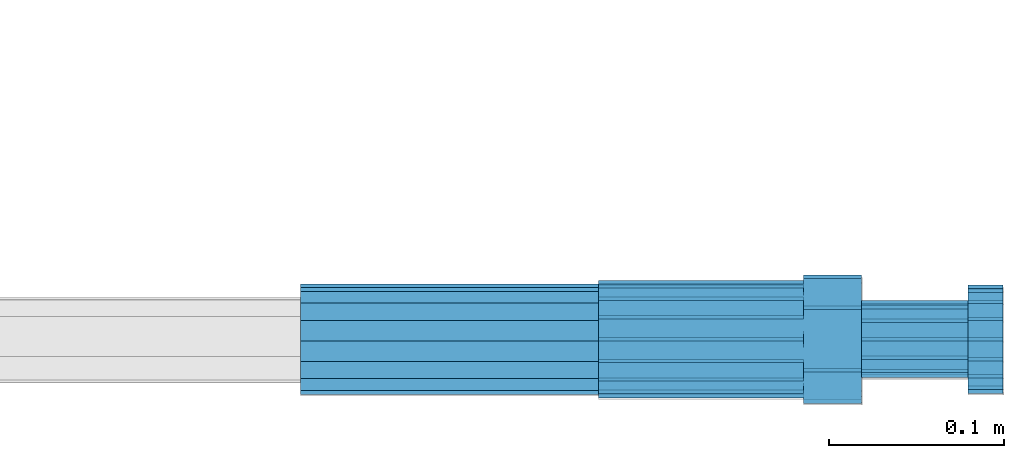
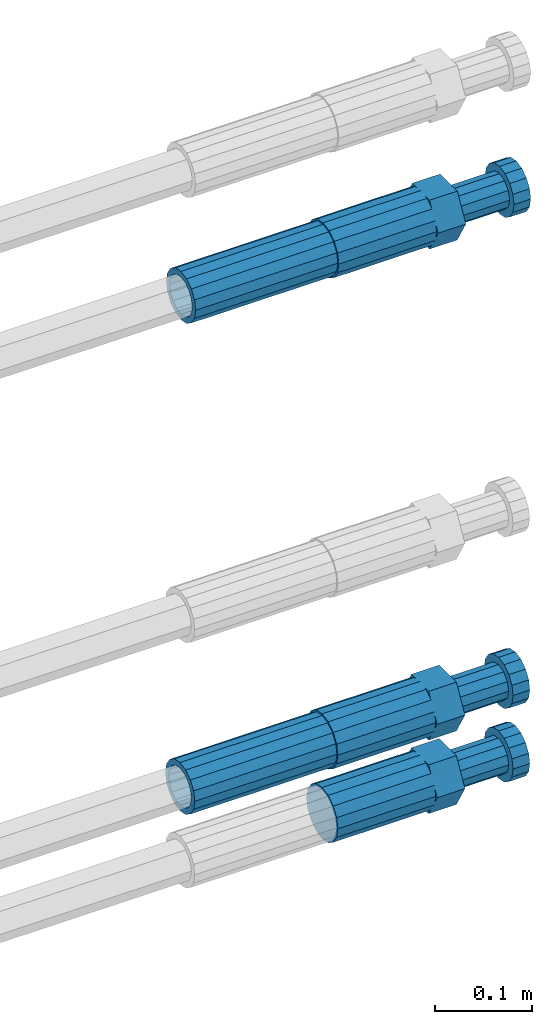
# One storey, part 106 of 177: 5 beams.
"""IFC2X3 building model written with IfcOpenShell, lengths in millimetres."""

from ifc_helpers import new_model, si_unit, frame, origin_with_axes, place, context, subcontext, project, spatial, faceted_brep, material, type_object, element, save


model = new_model("IFC2X3")

# Units and contexts
model_context_1 = context("Model", 3, precision=1e-05, world=origin_with_axes())
model_context_2 = context("Model", 3, precision=1e-05, world=origin_with_axes())
body_context = subcontext(model_context_2, "Body", "Model", "MODEL_VIEW")
ifc_project = project(units=[si_unit("LENGTHUNIT", "METRE", prefix="MILLI"), si_unit("AREAUNIT", "SQUARE_METRE"), si_unit("VOLUMEUNIT", "CUBIC_METRE"), si_unit("MASSUNIT", "GRAM", prefix="KILO"), si_unit("TIMEUNIT", "SECOND"), si_unit("PLANEANGLEUNIT", "RADIAN"), si_unit("SOLIDANGLEUNIT", "STERADIAN"), si_unit("THERMODYNAMICTEMPERATUREUNIT", "DEGREE_CELSIUS"), si_unit("LUMINOUSINTENSITYUNIT", "LUMEN")], contexts=[model_context_1])

# Site, building, storey
site_placement = place(None, origin_with_axes())
site = spatial("IfcSite", under=ifc_project, at=site_placement, CompositionType="ELEMENT")
building_placement = place(site_placement, origin_with_axes())
building = spatial("IfcBuilding", under=site, at=building_placement, Name="Undefined", CompositionType="ELEMENT")
storey_placement = place(building_placement, origin_with_axes())
storey = spatial("IfcBuildingStorey", under=building, at=storey_placement, Name="Undefined", CompositionType="ELEMENT", Elevation=0.0)

# Beams
ifc_material = material(Name="STEEL/S275")
beam_type_1 = type_object("IfcBeamType", PredefinedType="NOTDEFINED")
beam_1_placement = place(storey_placement, frame((2039349.04037948, 6205100.91588036, 18690.9968004305), z_axis=(0.0, 0.0, -1.0), x_axis=(1.0, 0.0, 0.0)))
element("IfcBeam", 1, at=beam_1_placement, inside=storey, type_object=beam_type_1, material=ifc_material, Name="AG40N", context=body_context, shape_type="Brep", body=[
    faceted_brep([(0.0, -23.5000000001164, -9.31322574615479e-10), (0.0, -21.7111690140155, 8.99306066054851), (170.0, -21.7111690140155, 8.99306066054851), (170.0, -23.5, 0.0), (0.0, -16.6170093578839, 16.6170093575493), (170.0, -16.6170093578839, 16.6170093575493), (0.0, -8.99306066057943, 21.7111690137535), (170.0, -8.99306066057943, 21.7111690137535), (0.0, 1.16415321826935e-10, 23.5), (170.0, 0.0, 23.5), (0.0, 8.99306066057943, 21.7111690137535), (170.0, 8.99306066057943, 21.7111690137535), (0.0, 16.6170093578839, 16.6170093575493), (170.0, 16.6170093578839, 16.6170093575493), (0.0, 21.7111690140155, 8.99306066054851), (170.0, 21.7111690140155, 8.99306066054851), (0.0, 23.5000000001164, -9.31322574615479e-10), (170.0, 23.5, 0.0), (0.0, 21.7111690140155, -8.99306066054851), (170.0, 21.7111690140155, -8.99306066054851), (0.0, 16.6170093578839, -16.6170093575493), (170.0, 16.6170093578839, -16.6170093575493), (0.0, 8.99306066057943, -21.7111690137535), (170.0, 8.99306066057943, -21.7111690137535), (0.0, 1.16415321826935e-10, -23.5000000009313), (170.0, 0.0, -23.5), (0.0, -8.99306066057943, -21.7111690137535), (170.0, -8.99306066057943, -21.7111690137535), (0.0, -16.6170093578839, -16.6170093575493), (170.0, -16.6170093578839, -16.6170093575493), (0.0, -21.7111690140155, -8.99306066054851), (170.0, -21.7111690140155, -8.99306066054851), (0.0, -30.5, 0.0), (0.0, -28.1783257415937, -11.6718446873128), (170.0, -28.1783257415937, -11.6718446873128), (170.0, -30.5, 0.0), (0.0, -21.5667568261888, -21.5667568258941), (170.0, -21.5667568261888, -21.5667568258941), (0.0, -11.6718446871346, -28.1783257415518), (170.0, -11.6718446871346, -28.1783257415518), (0.0, 0.0, -30.5), (170.0, 0.0, -30.5), (0.0, 11.6718446871346, -28.1783257415518), (170.0, 11.6718446871346, -28.1783257415518), (0.0, 21.5667568261888, -21.5667568258941), (170.0, 21.5667568261888, -21.5667568258941), (0.0, 28.1783257415937, -11.6718446873128), (170.0, 28.1783257415937, -11.6718446873128), (0.0, 30.5, 0.0), (170.0, 30.5, 0.0), (0.0, 28.1783257415937, 11.6718446873128), (170.0, 28.1783257415937, 11.6718446873128), (0.0, 21.5667568261888, 21.5667568258941), (170.0, 21.5667568261888, 21.5667568258941), (0.0, 11.6718446871346, 28.1783257415518), (170.0, 11.6718446871346, 28.1783257415518), (0.0, 0.0, 30.5), (170.0, 0.0, 30.5), (0.0, -11.6718446871346, 28.1783257415518), (170.0, -11.6718446871346, 28.1783257415518), (0.0, -21.5667568261888, 21.5667568258941), (170.0, -21.5667568261888, 21.5667568258941), (0.0, -28.1783257415937, 11.6718446873128), (170.0, -28.1783257415937, 11.6718446873128)], [[[0, 1, 2, 3]], [[1, 4, 5, 2]], [[4, 6, 7, 5]], [[6, 8, 9, 7]], [[8, 10, 11, 9]], [[10, 12, 13, 11]], [[12, 14, 15, 13]], [[14, 16, 17, 15]], [[16, 18, 19, 17]], [[18, 20, 21, 19]], [[20, 22, 23, 21]], [[22, 24, 25, 23]], [[24, 26, 27, 25]], [[26, 28, 29, 27]], [[28, 30, 31, 29]], [[30, 0, 3, 31]], [[32, 33, 34, 35]], [[33, 36, 37, 34]], [[36, 38, 39, 37]], [[38, 40, 41, 39]], [[40, 42, 43, 41]], [[42, 44, 45, 43]], [[44, 46, 47, 45]], [[46, 48, 49, 47]], [[48, 50, 51, 49]], [[50, 52, 53, 51]], [[52, 54, 55, 53]], [[54, 56, 57, 55]], [[56, 58, 59, 57]], [[58, 60, 61, 59]], [[60, 62, 63, 61]], [[62, 32, 35, 63]], [[37, 39, 41, 43, 45, 47, 49, 51, 53, 55, 57, 59, 61, 63, 35, 34], [5, 7, 9, 11, 13, 15, 17, 19, 21, 23, 25, 27, 29, 31, 3, 2]], [[62, 60, 58, 56, 54, 52, 50, 48, 46, 44, 42, 40, 38, 36, 33, 32], [30, 28, 26, 24, 22, 20, 18, 16, 14, 12, 10, 8, 6, 4, 1, 0]]]),
])
beam_2_placement = place(storey_placement, frame((2039349.02228821, 6205098.98588349, 19312.9867998308), z_axis=(0.0, 0.0, -1.0), x_axis=(1.0, 0.0, 0.0)))
element("IfcBeam", 2, at=beam_2_placement, inside=storey, type_object=beam_type_1, material=ifc_material, Name="AG40N", context=body_context, shape_type="Brep", body=[
    faceted_brep([(0.0, -23.5000000001164, -9.31322574615479e-10), (0.0, -21.7111690140155, 8.99306066054851), (170.0, -21.7111690140155, 8.99306066054851), (170.0, -23.5, 0.0), (0.0, -16.6170093578839, 16.6170093575493), (170.0, -16.6170093578839, 16.6170093575493), (0.0, -8.99306066057943, 21.7111690137535), (170.0, -8.99306066057943, 21.7111690137535), (0.0, 1.16415321826935e-10, 23.5), (170.0, 0.0, 23.5), (0.0, 8.99306066057943, 21.7111690137535), (170.0, 8.99306066057943, 21.7111690137535), (0.0, 16.6170093578839, 16.6170093575493), (170.0, 16.6170093578839, 16.6170093575493), (0.0, 21.7111690140155, 8.99306066054851), (170.0, 21.7111690140155, 8.99306066054851), (0.0, 23.5000000001164, -9.31322574615479e-10), (170.0, 23.5, 0.0), (0.0, 21.7111690140155, -8.99306066054851), (170.0, 21.7111690140155, -8.99306066054851), (0.0, 16.6170093578839, -16.6170093575493), (170.0, 16.6170093578839, -16.6170093575493), (0.0, 8.99306066057943, -21.7111690137535), (170.0, 8.99306066057943, -21.7111690137535), (0.0, 1.16415321826935e-10, -23.5000000009313), (170.0, 0.0, -23.5), (0.0, -8.99306066057943, -21.7111690137535), (170.0, -8.99306066057943, -21.7111690137535), (0.0, -16.6170093578839, -16.6170093575493), (170.0, -16.6170093578839, -16.6170093575493), (0.0, -21.7111690140155, -8.99306066054851), (170.0, -21.7111690140155, -8.99306066054851), (0.0, -30.5, 0.0), (0.0, -28.1783257415937, -11.6718446873128), (170.0, -28.1783257415937, -11.6718446873128), (170.0, -30.5, 0.0), (0.0, -21.5667568261888, -21.5667568258941), (170.0, -21.5667568261888, -21.5667568258941), (0.0, -11.6718446871346, -28.1783257415518), (170.0, -11.6718446871346, -28.1783257415518), (0.0, 0.0, -30.5), (170.0, 0.0, -30.5), (0.0, 11.6718446871346, -28.1783257415518), (170.0, 11.6718446871346, -28.1783257415518), (0.0, 21.5667568261888, -21.5667568258941), (170.0, 21.5667568261888, -21.5667568258941), (0.0, 28.1783257415937, -11.6718446873128), (170.0, 28.1783257415937, -11.6718446873128), (0.0, 30.5, 0.0), (170.0, 30.5, 0.0), (0.0, 28.1783257415937, 11.6718446873128), (170.0, 28.1783257415937, 11.6718446873128), (0.0, 21.5667568261888, 21.5667568258941), (170.0, 21.5667568261888, 21.5667568258941), (0.0, 11.6718446871346, 28.1783257415518), (170.0, 11.6718446871346, 28.1783257415518), (0.0, 0.0, 30.5), (170.0, 0.0, 30.5), (0.0, -11.6718446871346, 28.1783257415518), (170.0, -11.6718446871346, 28.1783257415518), (0.0, -21.5667568261888, 21.5667568258941), (170.0, -21.5667568261888, 21.5667568258941), (0.0, -28.1783257415937, 11.6718446873128), (170.0, -28.1783257415937, 11.6718446873128)], [[[0, 1, 2, 3]], [[1, 4, 5, 2]], [[4, 6, 7, 5]], [[6, 8, 9, 7]], [[8, 10, 11, 9]], [[10, 12, 13, 11]], [[12, 14, 15, 13]], [[14, 16, 17, 15]], [[16, 18, 19, 17]], [[18, 20, 21, 19]], [[20, 22, 23, 21]], [[22, 24, 25, 23]], [[24, 26, 27, 25]], [[26, 28, 29, 27]], [[28, 30, 31, 29]], [[30, 0, 3, 31]], [[32, 33, 34, 35]], [[33, 36, 37, 34]], [[36, 38, 39, 37]], [[38, 40, 41, 39]], [[40, 42, 43, 41]], [[42, 44, 45, 43]], [[44, 46, 47, 45]], [[46, 48, 49, 47]], [[48, 50, 51, 49]], [[50, 52, 53, 51]], [[52, 54, 55, 53]], [[54, 56, 57, 55]], [[56, 58, 59, 57]], [[58, 60, 61, 59]], [[60, 62, 63, 61]], [[62, 32, 35, 63]], [[37, 39, 41, 43, 45, 47, 49, 51, 53, 55, 57, 59, 61, 63, 35, 34], [5, 7, 9, 11, 13, 15, 17, 19, 21, 23, 25, 27, 29, 31, 3, 2]], [[62, 60, 58, 56, 54, 52, 50, 48, 46, 44, 42, 40, 38, 36, 33, 32], [30, 28, 26, 24, 22, 20, 18, 16, 14, 12, 10, 8, 6, 4, 1, 0]]]),
])
beam_type_2 = type_object("IfcBeamType", Name="ROD65", PredefinedType="NOTDEFINED")
beam_3_placement = place(storey_placement, frame((2039519.04037948, 6205100.91588036, 18597.9968004303), z_axis=(0.0, 0.0, -1.0), x_axis=(1.0, 0.0, 0.0)))
element("IfcBeam", 3, at=beam_3_placement, inside=storey, type_object=beam_type_2, material=ifc_material, Name="AGB40", ObjectType="ROD65", context=body_context, shape_type="Brep", body=[
    faceted_brep([(117.0, 8.17543110251427, 30.873805644922), (117.0, 17.8250000001863, 30.873805644922), (117.0, 22.0056958701462, 23.6326279877685), (117.0, 12.4372115517035, 30.0260848065373), (117.0, -17.8250000001863, 30.873805644922), (150.200000000186, -17.8250000001863, 30.873805644922), (150.200000000186, 17.8250000001863, 30.873805644922), (117.0, -8.17543110251427, 30.873805644922), (117.0, -12.4372115517035, 30.0260848065373), (117.0, -22.0056958701462, 23.6326279877685), (117.0, -35.6500000003725, 0.0), (150.200000000186, -35.6500000003725, 0.0), (117.0, -30.8443150008097, 8.32369058486074), (117.0, -32.5, 0.0), (117.0, -30.8443150008097, -8.32369058462791), (117.0, -17.8250000001863, -30.873805644922), (150.200000000186, -17.8250000001863, -30.873805644922), (117.0, -22.0056958701462, -23.6326279877685), (117.0, -12.4372115517035, -30.0260848065373), (117.0, -8.17543110251427, -30.873805644922), (117.0, 17.8250000001863, -30.873805644922), (150.200000000186, 17.8250000001863, -30.873805644922), (117.0, 8.17543110251427, -30.873805644922), (117.0, 22.0056958701462, -23.6326279877685), (117.0, 12.4372115517035, -30.0260848065373), (117.0, 35.6500000003725, 0.0), (150.200000000186, 35.6500000003725, 0.0), (117.0, 30.8443150008097, -8.32369058486074), (117.0, 30.8443150008097, 8.32369058462791), (117.0, 32.5, 0.0), (0.0, -22.9809703892097, 22.9809703885621), (0.0, -30.0260848058388, 12.4372115518636), (117.0, -30.0260848067701, 12.4372115519363), (117.0, -22.9809703882784, 22.9809703885112), (-2.3283064365387e-10, 22.9809703892097, -22.9809703885639), (-4.65661287307739e-10, 30.0260848077014, -12.4372115518672), (117.0, 30.0260848067701, -12.4372115519363), (117.0, 22.9809703882784, -22.9809703885112), (-2.3283064365387e-10, -30.0260848067701, -12.4372115518672), (-2.3283064365387e-10, -22.9809703892097, -22.9809703885621), (117.0, -22.9809703882784, -22.9809703885112), (117.0, -30.0260848067701, -12.4372115519363), (-2.3283064365387e-10, -12.4372115507722, 30.0260848066137), (-2.3283064365387e-10, 9.31322574615479e-10, 32.4999999999982), (-2.3283064365387e-10, 12.4372115526348, 30.0260848066137), (0.0, 22.9809703892097, 22.9809703885621), (-2.3283064365387e-10, 30.0260848077014, 12.4372115518636), (-2.3283064365387e-10, 32.5, 0.0), (-2.3283064365387e-10, 12.4372115526348, -30.0260848066173), (-2.3283064365387e-10, 9.31322574615479e-10, -32.5), (-2.3283064365387e-10, -12.4372115517035, -30.0260848066173), (-4.65661287307739e-10, -32.4999999990687, -1.81898940354586e-12), (117.0, 22.9809703882784, 22.9809703885112), (117.0, 30.0260848067701, 12.4372115519363), (117.0, 0.0, -32.5), (117.0, 0.0, 32.5), (150.200000000186, 10.5, -18.1865334794857), (150.200000000186, 0.0, -21.0), (150.200000000186, -10.5, -18.1865334794857), (150.200000000186, -18.18653347902, -10.5), (150.200000000186, -21.0, 0.0), (150.200000000186, -18.18653347902, 10.5), (150.200000000186, -10.5, 18.1865334794857), (150.200000000186, 0.0, 21.0), (150.200000000186, 10.5, 18.1865334794857), (150.200000000186, 18.18653347902, 10.5), (150.200000000186, 21.0, 0.0), (150.200000000186, 18.18653347902, -10.5), (210.980000000447, -18.18653347902, 10.5), (210.980000000447, -21.0, 0.0), (210.980000000447, -10.5, 18.1865334794857), (210.980000000447, 0.0, 21.0), (210.980000000447, 10.5, 18.1865334794857), (210.980000000447, 18.18653347902, 10.5), (210.980000000447, 21.0, 0.0), (210.980000000447, 18.18653347902, -10.5), (210.980000000447, 10.5, -18.1865334794857), (210.980000000447, 0.0, -21.0), (210.980000000447, -10.5, -18.1865334794857), (210.980000000447, -18.18653347902, -10.5), (211.001368442696, -27.7269937992096, -11.491116326768), (211.003082550167, -21.2238094303757, -21.223815418547), (231.002518367059, -21.2131944671273, -21.2132004550658), (231.000804259587, -27.7163788359612, -11.4805013632867), (211.001368440451, -11.4911085031927, -27.7269970395137), (231.000804257343, -11.4804935399443, -27.7163820760325), (210.996487071217, -0.0106065049767494, -30.0106107392348), (230.995922888109, 8.45827162265778e-06, -29.9999957757536), (210.989181586672, 11.46989420522, -27.7269970329944), (230.988617403564, 11.4805091684684, -27.7163820695132), (210.980564180623, 21.2025914648548, -21.2238154064398), (230.979999997515, 21.2132064281031, -21.2132004429586), (210.971946775022, 27.7057703435421, -11.4911163107026), (230.971382591913, 27.7163853067905, -11.4805013472214), (210.96464129175, 29.9893808094785, -0.0106149562634528), (230.964077108642, 29.9999957727268, 7.21774995326996e-09), (210.959759924415, 27.7057638689876, 11.4698863970116), (230.959195741307, 27.7163788322359, 11.4805013604928), (210.958045816944, 21.2025795001537, 21.2025854887906), (230.957481633835, 21.213194463402, 21.2132004522718), (210.95975992666, 11.4698785729706, 27.7057671097573), (230.959195743551, 11.480493536219, 27.7163820732385), (210.964641295894, -0.010623425245285, 29.9893808094785), (230.964077112785, -8.46199691295624e-06, 29.9999957729597), (210.971946780439, -11.4911241354421, 27.705767103238), (230.97138259733, -11.4805091721937, 27.7163820667192), (210.980564186488, -21.2238213950768, 21.2025854766835), (230.980000003379, -21.2132064318284, 21.2132004401647), (210.989181592089, -27.7270002737641, 11.4698863809463), (230.988617408981, -27.7163853105158, 11.4805013444275), (210.996487075361, -30.0106107397005, -0.0106149734929204), (230.995922892253, -29.9999957764521, -1.00117176771164e-08)], [[[0, 1, 2, 3]], [[4, 5, 6, 1, 0, 7]], [[4, 7, 8, 9]], [[10, 11, 5, 4, 9, 12]], [[10, 12, 13, 14]], [[15, 16, 11, 10, 14, 17]], [[15, 17, 18, 19]], [[20, 21, 16, 15, 19, 22]], [[23, 20, 22, 24]], [[25, 26, 21, 20, 23, 27]], [[28, 25, 27, 29]], [[30, 31, 32, 33]], [[34, 35, 36, 37]], [[38, 39, 40, 41]], [[31, 30, 42, 43, 44, 45, 46, 47, 35, 34, 48, 49, 50, 39, 38, 51]], [[46, 45, 52, 53]], [[29, 47, 46, 53, 28]], [[27, 36, 35, 47, 29]], [[23, 37, 36, 27]], [[24, 48, 34, 37, 23]], [[22, 54, 49, 48, 24]], [[19, 54, 22]], [[18, 50, 49, 54, 19]], [[17, 40, 39, 50, 18]], [[14, 41, 40, 17]], [[13, 51, 38, 41, 14]], [[12, 32, 31, 51, 13]], [[9, 33, 32, 12]], [[8, 42, 30, 33, 9]], [[7, 55, 43, 42, 8]], [[0, 55, 7]], [[3, 44, 43, 55, 0]], [[2, 52, 45, 44, 3]], [[28, 53, 52, 2]], [[1, 6, 26, 25, 28, 2]], [[5, 11, 16, 21, 26, 6], [56, 57, 58, 59, 60, 61, 62, 63, 64, 65, 66, 67]], [[68, 61, 60, 69]], [[70, 62, 61, 68]], [[71, 63, 62, 70]], [[72, 64, 63, 71]], [[73, 65, 64, 72]], [[74, 66, 65, 73]], [[75, 67, 66, 74]], [[76, 56, 67, 75]], [[77, 57, 56, 76]], [[78, 58, 57, 77]], [[79, 59, 58, 78]], [[69, 60, 59, 79]], [[80, 81, 82, 83]], [[81, 84, 85, 82]], [[84, 86, 87, 85]], [[86, 88, 89, 87]], [[88, 90, 91, 89]], [[90, 92, 93, 91]], [[92, 94, 95, 93]], [[94, 96, 97, 95]], [[96, 98, 99, 97]], [[98, 100, 101, 99]], [[100, 102, 103, 101]], [[102, 104, 105, 103]], [[104, 106, 107, 105]], [[106, 108, 109, 107]], [[108, 110, 111, 109]], [[82, 85, 87, 89, 91, 93, 95, 97, 99, 101, 103, 105, 107, 109, 111, 83]], [[110, 80, 83, 111]], [[108, 106, 104, 102, 100, 98, 96, 94, 92, 90, 88, 86, 84, 81, 80, 110], [75, 74, 73, 72, 71, 70, 68, 69, 79, 78, 77, 76]]]),
])
beam_4_placement = place(storey_placement, frame((2039519.04037948, 6205100.91588036, 18690.9968004303), z_axis=(0.0, 0.0, -1.0), x_axis=(1.0, 0.0, 0.0)))
element("IfcBeam", 4, at=beam_4_placement, inside=storey, type_object=beam_type_2, material=ifc_material, Name="AGB40", ObjectType="ROD65", context=body_context, shape_type="Brep", body=[
    faceted_brep([(117.0, 8.17543110251427, 30.873805644922), (117.0, 17.8250000001863, 30.873805644922), (117.0, 22.0056958701462, 23.6326279877685), (117.0, 12.4372115517035, 30.0260848065373), (117.0, -17.8250000001863, 30.873805644922), (150.200000000186, -17.8250000001863, 30.873805644922), (150.200000000186, 17.8250000001863, 30.873805644922), (117.0, -8.17543110251427, 30.873805644922), (117.0, -12.4372115517035, 30.0260848065373), (117.0, -22.0056958701462, 23.6326279877685), (117.0, -35.6500000003725, 0.0), (150.200000000186, -35.6500000003725, 0.0), (117.0, -30.8443150008097, 8.32369058486074), (117.0, -32.5, 0.0), (117.0, -30.8443150008097, -8.32369058462791), (117.0, -17.8250000001863, -30.873805644922), (150.200000000186, -17.8250000001863, -30.873805644922), (117.0, -22.0056958701462, -23.6326279877685), (117.0, -12.4372115517035, -30.0260848065373), (117.0, -8.17543110251427, -30.873805644922), (117.0, 17.8250000001863, -30.873805644922), (150.200000000186, 17.8250000001863, -30.873805644922), (117.0, 8.17543110251427, -30.873805644922), (117.0, 22.0056958701462, -23.6326279877685), (117.0, 12.4372115517035, -30.0260848065373), (117.0, 35.6500000003725, 0.0), (150.200000000186, 35.6500000003725, 0.0), (117.0, 30.8443150008097, -8.32369058486074), (117.0, 30.8443150008097, 8.32369058462791), (117.0, 32.5, 0.0), (0.0, -22.9809703892097, 22.9809703885621), (0.0, -30.0260848058388, 12.4372115518636), (117.0, -30.0260848067701, 12.4372115519363), (117.0, -22.9809703882784, 22.9809703885112), (-2.3283064365387e-10, 22.9809703892097, -22.9809703885639), (-4.65661287307739e-10, 30.0260848077014, -12.4372115518672), (117.0, 30.0260848067701, -12.4372115519363), (117.0, 22.9809703882784, -22.9809703885112), (-2.3283064365387e-10, -30.0260848067701, -12.4372115518672), (-2.3283064365387e-10, -22.9809703892097, -22.9809703885621), (117.0, -22.9809703882784, -22.9809703885112), (117.0, -30.0260848067701, -12.4372115519363), (-2.3283064365387e-10, -12.4372115507722, 30.0260848066137), (-2.3283064365387e-10, 9.31322574615479e-10, 32.4999999999982), (-2.3283064365387e-10, 12.4372115526348, 30.0260848066137), (0.0, 22.9809703892097, 22.9809703885621), (-2.3283064365387e-10, 30.0260848077014, 12.4372115518636), (-2.3283064365387e-10, 32.5, 0.0), (-2.3283064365387e-10, 12.4372115526348, -30.0260848066173), (-2.3283064365387e-10, 9.31322574615479e-10, -32.5), (-2.3283064365387e-10, -12.4372115517035, -30.0260848066173), (-4.65661287307739e-10, -32.4999999990687, -1.81898940354586e-12), (117.0, 22.9809703882784, 22.9809703885112), (117.0, 30.0260848067701, 12.4372115519363), (117.0, 0.0, -32.5), (117.0, 0.0, 32.5), (150.200000000186, 10.5, -18.1865334794857), (150.200000000186, 0.0, -21.0), (150.200000000186, -10.5, -18.1865334794857), (150.200000000186, -18.18653347902, -10.5), (150.200000000186, -21.0, 0.0), (150.200000000186, -18.18653347902, 10.5), (150.200000000186, -10.5, 18.1865334794857), (150.200000000186, 0.0, 21.0), (150.200000000186, 10.5, 18.1865334794857), (150.200000000186, 18.18653347902, 10.5), (150.200000000186, 21.0, 0.0), (150.200000000186, 18.18653347902, -10.5), (210.980000000447, -18.18653347902, 10.5), (210.980000000447, -21.0, 0.0), (210.980000000447, -10.5, 18.1865334794857), (210.980000000447, 0.0, 21.0), (210.980000000447, 10.5, 18.1865334794857), (210.980000000447, 18.18653347902, 10.5), (210.980000000447, 21.0, 0.0), (210.980000000447, 18.18653347902, -10.5), (210.980000000447, 10.5, -18.1865334794857), (210.980000000447, 0.0, -21.0), (210.980000000447, -10.5, -18.1865334794857), (210.980000000447, -18.18653347902, -10.5), (211.001368442696, -27.7269937992096, -11.491116326768), (211.003082550167, -21.2238094303757, -21.223815418547), (231.002518367059, -21.2131944671273, -21.2132004550658), (231.000804259587, -27.7163788359612, -11.4805013632867), (211.001368440451, -11.4911085031927, -27.7269970395137), (231.000804257343, -11.4804935399443, -27.7163820760325), (210.996487071217, -0.0106065049767494, -30.0106107392348), (230.995922888109, 8.45827162265778e-06, -29.9999957757536), (210.989181586672, 11.46989420522, -27.7269970329944), (230.988617403564, 11.4805091684684, -27.7163820695132), (210.980564180623, 21.2025914648548, -21.2238154064398), (230.979999997515, 21.2132064281031, -21.2132004429586), (210.971946775022, 27.7057703435421, -11.4911163107026), (230.971382591913, 27.7163853067905, -11.4805013472214), (210.96464129175, 29.9893808094785, -0.0106149562634528), (230.964077108642, 29.9999957727268, 7.21774995326996e-09), (210.959759924415, 27.7057638689876, 11.4698863970116), (230.959195741307, 27.7163788322359, 11.4805013604928), (210.958045816944, 21.2025795001537, 21.2025854887906), (230.957481633835, 21.213194463402, 21.2132004522718), (210.95975992666, 11.4698785729706, 27.7057671097573), (230.959195743551, 11.480493536219, 27.7163820732385), (210.964641295894, -0.010623425245285, 29.9893808094785), (230.964077112785, -8.46199691295624e-06, 29.9999957729597), (210.971946780439, -11.4911241354421, 27.705767103238), (230.97138259733, -11.4805091721937, 27.7163820667192), (210.980564186488, -21.2238213950768, 21.2025854766835), (230.980000003379, -21.2132064318284, 21.2132004401647), (210.989181592089, -27.7270002737641, 11.4698863809463), (230.988617408981, -27.7163853105158, 11.4805013444275), (210.996487075361, -30.0106107397005, -0.0106149734929204), (230.995922892253, -29.9999957764521, -1.00117176771164e-08)], [[[0, 1, 2, 3]], [[4, 5, 6, 1, 0, 7]], [[4, 7, 8, 9]], [[10, 11, 5, 4, 9, 12]], [[10, 12, 13, 14]], [[15, 16, 11, 10, 14, 17]], [[15, 17, 18, 19]], [[20, 21, 16, 15, 19, 22]], [[23, 20, 22, 24]], [[25, 26, 21, 20, 23, 27]], [[28, 25, 27, 29]], [[30, 31, 32, 33]], [[34, 35, 36, 37]], [[38, 39, 40, 41]], [[31, 30, 42, 43, 44, 45, 46, 47, 35, 34, 48, 49, 50, 39, 38, 51]], [[46, 45, 52, 53]], [[29, 47, 46, 53, 28]], [[27, 36, 35, 47, 29]], [[23, 37, 36, 27]], [[24, 48, 34, 37, 23]], [[22, 54, 49, 48, 24]], [[19, 54, 22]], [[18, 50, 49, 54, 19]], [[17, 40, 39, 50, 18]], [[14, 41, 40, 17]], [[13, 51, 38, 41, 14]], [[12, 32, 31, 51, 13]], [[9, 33, 32, 12]], [[8, 42, 30, 33, 9]], [[7, 55, 43, 42, 8]], [[0, 55, 7]], [[3, 44, 43, 55, 0]], [[2, 52, 45, 44, 3]], [[28, 53, 52, 2]], [[1, 6, 26, 25, 28, 2]], [[5, 11, 16, 21, 26, 6], [56, 57, 58, 59, 60, 61, 62, 63, 64, 65, 66, 67]], [[68, 61, 60, 69]], [[70, 62, 61, 68]], [[71, 63, 62, 70]], [[72, 64, 63, 71]], [[73, 65, 64, 72]], [[74, 66, 65, 73]], [[75, 67, 66, 74]], [[76, 56, 67, 75]], [[77, 57, 56, 76]], [[78, 58, 57, 77]], [[79, 59, 58, 78]], [[69, 60, 59, 79]], [[80, 81, 82, 83]], [[81, 84, 85, 82]], [[84, 86, 87, 85]], [[86, 88, 89, 87]], [[88, 90, 91, 89]], [[90, 92, 93, 91]], [[92, 94, 95, 93]], [[94, 96, 97, 95]], [[96, 98, 99, 97]], [[98, 100, 101, 99]], [[100, 102, 103, 101]], [[102, 104, 105, 103]], [[104, 106, 107, 105]], [[106, 108, 109, 107]], [[108, 110, 111, 109]], [[82, 85, 87, 89, 91, 93, 95, 97, 99, 101, 103, 105, 107, 109, 111, 83]], [[110, 80, 83, 111]], [[108, 106, 104, 102, 100, 98, 96, 94, 92, 90, 88, 86, 84, 81, 80, 110], [75, 74, 73, 72, 71, 70, 68, 69, 79, 78, 77, 76]]]),
])
beam_5_placement = place(storey_placement, frame((2039519.02228821, 6205098.98588349, 19312.9867998307), z_axis=(0.0, 0.0, -1.0), x_axis=(1.0, 0.0, 0.0)))
element("IfcBeam", 5, at=beam_5_placement, inside=storey, type_object=beam_type_2, material=ifc_material, Name="AGB40", ObjectType="ROD65", context=body_context, shape_type="Brep", body=[
    faceted_brep([(117.0, 8.17543110251427, 30.873805644922), (117.0, 17.8250000001863, 30.873805644922), (117.0, 22.0056958701462, 23.6326279877685), (117.0, 12.4372115517035, 30.0260848065373), (117.0, -17.8250000001863, 30.873805644922), (150.200000000186, -17.8250000001863, 30.873805644922), (150.200000000186, 17.8250000001863, 30.873805644922), (117.0, -8.17543110251427, 30.873805644922), (117.0, -12.4372115517035, 30.0260848065373), (117.0, -22.0056958701462, 23.6326279877685), (117.0, -35.6500000003725, 0.0), (150.200000000186, -35.6500000003725, 0.0), (117.0, -30.8443150008097, 8.32369058486074), (117.0, -32.5, 0.0), (117.0, -30.8443150008097, -8.32369058462791), (117.0, -17.8250000001863, -30.873805644922), (150.200000000186, -17.8250000001863, -30.873805644922), (117.0, -22.0056958701462, -23.6326279877685), (117.0, -12.4372115517035, -30.0260848065373), (117.0, -8.17543110251427, -30.873805644922), (117.0, 17.8250000001863, -30.873805644922), (150.200000000186, 17.8250000001863, -30.873805644922), (117.0, 8.17543110251427, -30.873805644922), (117.0, 22.0056958701462, -23.6326279877685), (117.0, 12.4372115517035, -30.0260848065373), (117.0, 35.6500000003725, 0.0), (150.200000000186, 35.6500000003725, 0.0), (117.0, 30.8443150008097, -8.32369058486074), (117.0, 30.8443150008097, 8.32369058462791), (117.0, 32.5, 0.0), (0.0, -22.9809703892097, 22.9809703885621), (0.0, -30.0260848058388, 12.4372115518636), (117.0, -30.0260848067701, 12.4372115519363), (117.0, -22.9809703882784, 22.9809703885112), (-2.3283064365387e-10, 22.9809703892097, -22.9809703885639), (-4.65661287307739e-10, 30.0260848077014, -12.4372115518672), (117.0, 30.0260848067701, -12.4372115519363), (117.0, 22.9809703882784, -22.9809703885112), (-2.3283064365387e-10, -30.0260848067701, -12.4372115518672), (-2.3283064365387e-10, -22.9809703892097, -22.9809703885621), (117.0, -22.9809703882784, -22.9809703885112), (117.0, -30.0260848067701, -12.4372115519363), (-2.3283064365387e-10, -12.4372115507722, 30.0260848066137), (-2.3283064365387e-10, 9.31322574615479e-10, 32.4999999999982), (-2.3283064365387e-10, 12.4372115526348, 30.0260848066137), (0.0, 22.9809703892097, 22.9809703885621), (-2.3283064365387e-10, 30.0260848077014, 12.4372115518636), (-2.3283064365387e-10, 32.5, 0.0), (-2.3283064365387e-10, 12.4372115526348, -30.0260848066173), (-2.3283064365387e-10, 9.31322574615479e-10, -32.5), (-2.3283064365387e-10, -12.4372115517035, -30.0260848066173), (-4.65661287307739e-10, -32.4999999990687, -1.81898940354586e-12), (117.0, 22.9809703882784, 22.9809703885112), (117.0, 30.0260848067701, 12.4372115519363), (117.0, 0.0, -32.5), (117.0, 0.0, 32.5), (150.200000000186, 10.5, -18.1865334794857), (150.200000000186, 0.0, -21.0), (150.200000000186, -10.5, -18.1865334794857), (150.200000000186, -18.18653347902, -10.5), (150.200000000186, -21.0, 0.0), (150.200000000186, -18.18653347902, 10.5), (150.200000000186, -10.5, 18.1865334794857), (150.200000000186, 0.0, 21.0), (150.200000000186, 10.5, 18.1865334794857), (150.200000000186, 18.18653347902, 10.5), (150.200000000186, 21.0, 0.0), (150.200000000186, 18.18653347902, -10.5), (210.980000000447, -18.18653347902, 10.5), (210.980000000447, -21.0, 0.0), (210.980000000447, -10.5, 18.1865334794857), (210.980000000447, 0.0, 21.0), (210.980000000447, 10.5, 18.1865334794857), (210.980000000447, 18.18653347902, 10.5), (210.980000000447, 21.0, 0.0), (210.980000000447, 18.18653347902, -10.5), (210.980000000447, 10.5, -18.1865334794857), (210.980000000447, 0.0, -21.0), (210.980000000447, -10.5, -18.1865334794857), (210.980000000447, -18.18653347902, -10.5), (211.001368442696, -27.7269937992096, -11.491116326768), (211.003082550167, -21.2238094303757, -21.223815418547), (231.002518367059, -21.2131944671273, -21.2132004550658), (231.000804259587, -27.7163788359612, -11.4805013632867), (211.001368440451, -11.4911085031927, -27.7269970395137), (231.000804257343, -11.4804935399443, -27.7163820760325), (210.996487071217, -0.0106065049767494, -30.0106107392348), (230.995922888109, 8.45827162265778e-06, -29.9999957757536), (210.989181586672, 11.46989420522, -27.7269970329944), (230.988617403564, 11.4805091684684, -27.7163820695132), (210.980564180623, 21.2025914648548, -21.2238154064398), (230.979999997515, 21.2132064281031, -21.2132004429586), (210.971946775022, 27.7057703435421, -11.4911163107026), (230.971382591913, 27.7163853067905, -11.4805013472214), (210.96464129175, 29.9893808094785, -0.0106149562634528), (230.964077108642, 29.9999957727268, 7.21774995326996e-09), (210.959759924415, 27.7057638689876, 11.4698863970116), (230.959195741307, 27.7163788322359, 11.4805013604928), (210.958045816944, 21.2025795001537, 21.2025854887906), (230.957481633835, 21.213194463402, 21.2132004522718), (210.95975992666, 11.4698785729706, 27.7057671097573), (230.959195743551, 11.480493536219, 27.7163820732385), (210.964641295894, -0.010623425245285, 29.9893808094785), (230.964077112785, -8.46199691295624e-06, 29.9999957729597), (210.971946780439, -11.4911241354421, 27.705767103238), (230.97138259733, -11.4805091721937, 27.7163820667192), (210.980564186488, -21.2238213950768, 21.2025854766835), (230.980000003379, -21.2132064318284, 21.2132004401647), (210.989181592089, -27.7270002737641, 11.4698863809463), (230.988617408981, -27.7163853105158, 11.4805013444275), (210.996487075361, -30.0106107397005, -0.0106149734929204), (230.995922892253, -29.9999957764521, -1.00117176771164e-08)], [[[0, 1, 2, 3]], [[4, 5, 6, 1, 0, 7]], [[4, 7, 8, 9]], [[10, 11, 5, 4, 9, 12]], [[10, 12, 13, 14]], [[15, 16, 11, 10, 14, 17]], [[15, 17, 18, 19]], [[20, 21, 16, 15, 19, 22]], [[23, 20, 22, 24]], [[25, 26, 21, 20, 23, 27]], [[28, 25, 27, 29]], [[30, 31, 32, 33]], [[34, 35, 36, 37]], [[38, 39, 40, 41]], [[31, 30, 42, 43, 44, 45, 46, 47, 35, 34, 48, 49, 50, 39, 38, 51]], [[46, 45, 52, 53]], [[29, 47, 46, 53, 28]], [[27, 36, 35, 47, 29]], [[23, 37, 36, 27]], [[24, 48, 34, 37, 23]], [[22, 54, 49, 48, 24]], [[19, 54, 22]], [[18, 50, 49, 54, 19]], [[17, 40, 39, 50, 18]], [[14, 41, 40, 17]], [[13, 51, 38, 41, 14]], [[12, 32, 31, 51, 13]], [[9, 33, 32, 12]], [[8, 42, 30, 33, 9]], [[7, 55, 43, 42, 8]], [[0, 55, 7]], [[3, 44, 43, 55, 0]], [[2, 52, 45, 44, 3]], [[28, 53, 52, 2]], [[1, 6, 26, 25, 28, 2]], [[5, 11, 16, 21, 26, 6], [56, 57, 58, 59, 60, 61, 62, 63, 64, 65, 66, 67]], [[68, 61, 60, 69]], [[70, 62, 61, 68]], [[71, 63, 62, 70]], [[72, 64, 63, 71]], [[73, 65, 64, 72]], [[74, 66, 65, 73]], [[75, 67, 66, 74]], [[76, 56, 67, 75]], [[77, 57, 56, 76]], [[78, 58, 57, 77]], [[79, 59, 58, 78]], [[69, 60, 59, 79]], [[80, 81, 82, 83]], [[81, 84, 85, 82]], [[84, 86, 87, 85]], [[86, 88, 89, 87]], [[88, 90, 91, 89]], [[90, 92, 93, 91]], [[92, 94, 95, 93]], [[94, 96, 97, 95]], [[96, 98, 99, 97]], [[98, 100, 101, 99]], [[100, 102, 103, 101]], [[102, 104, 105, 103]], [[104, 106, 107, 105]], [[106, 108, 109, 107]], [[108, 110, 111, 109]], [[82, 85, 87, 89, 91, 93, 95, 97, 99, 101, 103, 105, 107, 109, 111, 83]], [[110, 80, 83, 111]], [[108, 106, 104, 102, 100, 98, 96, 94, 92, 90, 88, 86, 84, 81, 80, 110], [75, 74, 73, 72, 71, 70, 68, 69, 79, 78, 77, 76]]]),
])

save(model, "model.ifc")
